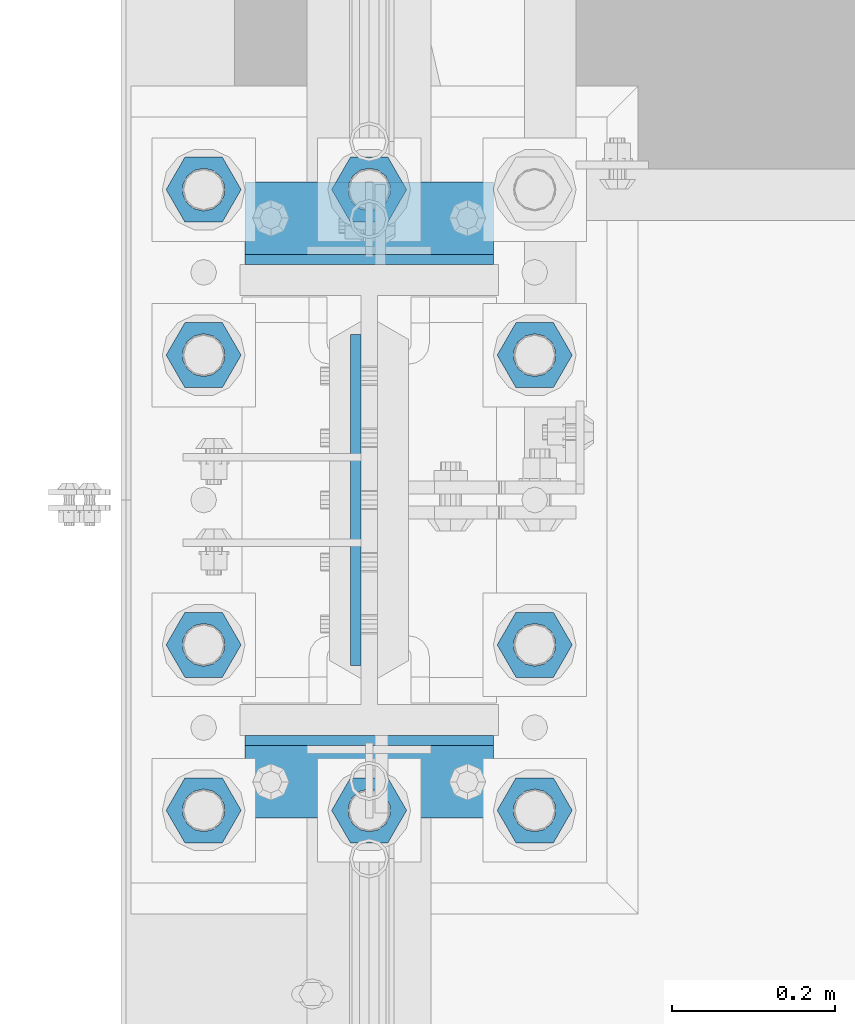
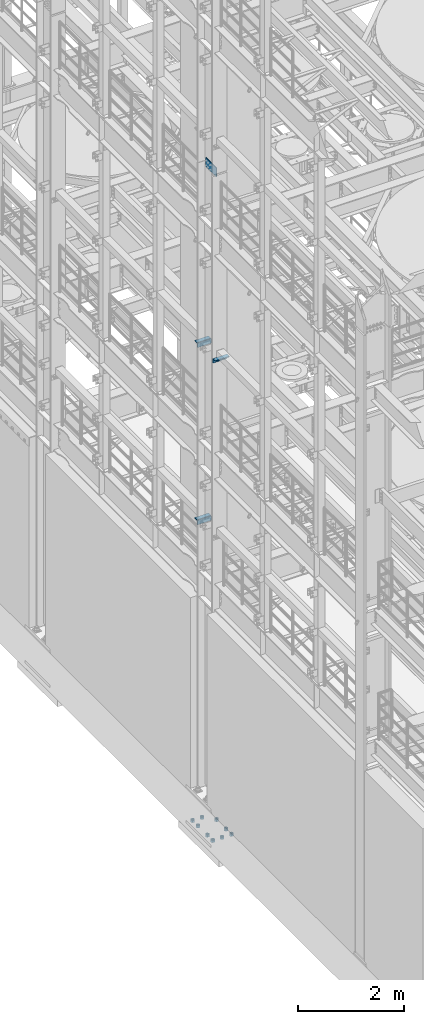
# One storey, part 1237 of 1876: 16 beams, 5 elements without a shape of their own.
"""IFC2X3 building model written with IfcOpenShell, lengths in millimetres."""

from ifc_helpers import new_model, si_unit, frame, origin_with_axes, place, context, subcontext, project, spatial, faceted_brep, material, type_object, element, aggregate, save


model = new_model("IFC2X3")

# Units and contexts
model_context = context("Model", 3, precision=1e-05, world=origin_with_axes())
body_context = subcontext(model_context, "Body", "Model", "MODEL_VIEW")
ifc_project = project(units=[si_unit("LENGTHUNIT", "METRE", prefix="MILLI"), si_unit("AREAUNIT", "SQUARE_METRE"), si_unit("VOLUMEUNIT", "CUBIC_METRE"), si_unit("MASSUNIT", "GRAM", prefix="KILO"), si_unit("TIMEUNIT", "SECOND"), si_unit("PLANEANGLEUNIT", "RADIAN"), si_unit("SOLIDANGLEUNIT", "STERADIAN"), si_unit("THERMODYNAMICTEMPERATUREUNIT", "DEGREE_CELSIUS"), si_unit("LUMINOUSINTENSITYUNIT", "LUMEN")], contexts=[model_context])

# Site, building, storey
site_placement = place(None, origin_with_axes())
site = spatial("IfcSite", under=ifc_project, at=site_placement, CompositionType="ELEMENT")
building_placement = place(site_placement, origin_with_axes())
building = spatial("IfcBuilding", under=site, at=building_placement, Name="Undefined", CompositionType="ELEMENT")
storey_placement = place(building_placement, origin_with_axes())
storey = spatial("IfcBuildingStorey", under=building, at=storey_placement, Name="Undefined", CompositionType="ELEMENT", Elevation=0.0)

# Assembly, beam
assembly_1_placement = place(storey_placement, origin_with_axes())
assembly_1 = element("IfcElementAssembly", 1, at=assembly_1_placement, inside=storey, Name="BEAM", AssemblyPlace="NOTDEFINED", PredefinedType="RIGID_FRAME")
ifc_material_1 = material(Name="STEEL/A36")
beam_type_1 = type_object("IfcBeamType", PredefinedType="NOTDEFINED")
beam_1_placement = place(assembly_1_placement, frame((-152.400000000001, 1177.925, 10339.3875), z_axis=(0.0, -1.0, 0.0), x_axis=(1.0, 0.0, 0.0)))
beam_1 = element("IfcBeam", 2, at=beam_1_placement, type_object=beam_type_1, material=ifc_material_1, Name="PLATE", context=body_context, shape_type="Brep", body=[
    faceted_brep([(0.0, 4.76250000000073, -44.4499999999998), (0.0, 4.76250000000073, 44.4499999999998), (304.799999999999, 4.76250000000073, 44.4499999999998), (304.799999999999, 4.76250000000073, -44.4499999999998), (0.0, -4.76250000000073, 44.4499999999998), (304.799999999999, -4.76250000000073, 44.4499999999998), (0.0, -4.76250000000073, -44.4499999999998), (304.799999999999, -4.76250000000073, -44.4499999999998)], [[[0, 1, 2, 3]], [[1, 4, 5, 2]], [[4, 6, 7, 5]], [[6, 0, 3, 7]], [[5, 7, 3, 2]], [[6, 4, 1, 0]]]),
])
aggregate(assembly_1, [beam_1])

assembly_2_placement = place(storey_placement, origin_with_axes())
assembly_2 = element("IfcElementAssembly", 3, at=assembly_2_placement, inside=storey, Name="BEAM", AssemblyPlace="NOTDEFINED", PredefinedType="RIGID_FRAME")
beam_2_placement = place(assembly_2_placement, frame((-152.400000000001, 1870.075, 10339.3875), z_axis=(0.0, 1.0, 0.0), x_axis=(1.0, 0.0, 0.0)))
beam_2 = element("IfcBeam", 4, at=beam_2_placement, type_object=beam_type_1, material=ifc_material_1, Name="PLATE", context=body_context, shape_type="Brep", body=[
    faceted_brep([(0.0, 4.76250000000073, -44.4499999999998), (0.0, 4.76250000000073, 44.4499999999998), (304.799999999999, 4.76250000000073, 44.4499999999998), (304.799999999999, 4.76250000000073, -44.4499999999998), (0.0, -4.76250000000073, 44.4499999999998), (304.799999999999, -4.76250000000073, 44.4499999999998), (0.0, -4.76250000000073, -44.4499999999998), (304.799999999999, -4.76250000000073, -44.4499999999998)], [[[0, 1, 2, 3]], [[1, 4, 5, 2]], [[4, 6, 7, 5]], [[6, 0, 3, 7]], [[5, 7, 3, 2]], [[6, 4, 1, 0]]]),
])
aggregate(assembly_2, [beam_2])

assembly_3_placement = place(storey_placement, origin_with_axes())
assembly_3 = element("IfcElementAssembly", 5, at=assembly_3_placement, inside=storey, Name="BEAM", AssemblyPlace="NOTDEFINED", PredefinedType="RIGID_FRAME")
beam_3_placement = place(assembly_3_placement, frame((-152.400000000001, 1870.075, 6249.9875), z_axis=(0.0, 1.0, 0.0), x_axis=(1.0, 0.0, 0.0)))
beam_3 = element("IfcBeam", 6, at=beam_3_placement, type_object=beam_type_1, material=ifc_material_1, Name="PLATE", context=body_context, shape_type="Brep", body=[
    faceted_brep([(0.0, 4.76250000000073, -44.4499999999998), (0.0, 4.76250000000073, 44.4499999999998), (304.799999999999, 4.76250000000073, 44.4499999999998), (304.799999999999, 4.76250000000073, -44.4499999999998), (0.0, -4.76250000000073, 44.4499999999998), (304.799999999999, -4.76250000000073, 44.4499999999998), (0.0, -4.76250000000073, -44.4499999999998), (304.799999999999, -4.76250000000073, -44.4499999999998)], [[[0, 1, 2, 3]], [[1, 4, 5, 2]], [[4, 6, 7, 5]], [[6, 0, 3, 7]], [[5, 7, 3, 2]], [[6, 4, 1, 0]]]),
])
aggregate(assembly_3, [beam_3])

# Assembly, beams
assembly_4_placement = place(storey_placement, origin_with_axes())
assembly_4 = element("IfcElementAssembly", 7, at=assembly_4_placement, inside=storey, Name="COLUMN", AssemblyPlace="NOTDEFINED", PredefinedType="RIGID_FRAME")
beam_type_2 = type_object("IfcBeamType", Name="L4X4X3/8", PredefinedType="NOTDEFINED")
beam_4_placement = place(assembly_4_placement, frame((-152.400000000001, 1184.275, 10283.825), z_axis=(0.0, -1.0, 0.0), x_axis=(1.0, 0.0, 0.0)))
beam_4 = element("IfcBeam", 8, at=beam_4_placement, type_object=beam_type_2, material=ifc_material_1, Name="ANGLE", ObjectType="L4X4X3/8", context=body_context, shape_type="Brep", body=[
    faceted_brep([(0.0, 50.7999999999993, -50.8000000000002), (0.0, 50.7999999999993, 50.8000000000002), (304.799999999999, 50.7999999999993, 50.8000000000002), (304.799999999999, 50.7999999999993, -50.8000000000002), (0.0, 41.2750000000015, 50.8000000000002), (304.799999999999, 41.2750000000015, 50.8000000000002), (0.0, 41.2750000000015, -41.2749999999996), (304.799999999999, 41.2750000000015, -41.2749999999996), (0.0, -50.7999999999993, -41.2749999999996), (304.799999999999, -50.7999999999993, -41.2749999999996), (0.0, -50.7999999999993, -50.8000000000002), (304.799999999999, -50.7999999999993, -50.8000000000002)], [[[0, 1, 2, 3]], [[1, 4, 5, 2]], [[4, 6, 7, 5]], [[6, 8, 9, 7]], [[8, 10, 11, 9]], [[10, 0, 3, 11]], [[5, 7, 9, 11, 3, 2]], [[10, 8, 6, 4, 1, 0]]]),
])
beam_5_placement = place(assembly_4_placement, frame((152.4, 1863.725, 10283.825), z_axis=(0.0, 1.0, 0.0), x_axis=(-1.0, 0.0, 0.0)))
beam_5 = element("IfcBeam", 9, at=beam_5_placement, type_object=beam_type_2, material=ifc_material_1, Name="ANGLE", ObjectType="L4X4X3/8", context=body_context, shape_type="Brep", body=[
    faceted_brep([(0.0, 50.7999999999993, -50.8000000000002), (0.0, 50.7999999999993, 50.8000000000002), (304.799999999999, 50.7999999999993, 50.8000000000002), (304.799999999999, 50.7999999999993, -50.8000000000002), (0.0, 41.2750000000015, 50.8000000000002), (304.799999999999, 41.2750000000015, 50.8000000000002), (0.0, 41.2750000000015, -41.2749999999996), (304.799999999999, 41.2750000000015, -41.2749999999996), (0.0, -50.7999999999993, -41.2749999999996), (304.799999999999, -50.7999999999993, -41.2749999999996), (0.0, -50.7999999999993, -50.8000000000002), (304.799999999999, -50.7999999999993, -50.8000000000002)], [[[0, 1, 2, 3]], [[1, 4, 5, 2]], [[4, 6, 7, 5]], [[6, 8, 9, 7]], [[8, 10, 11, 9]], [[10, 0, 3, 11]], [[5, 7, 9, 11, 3, 2]], [[10, 8, 6, 4, 1, 0]]]),
])
beam_6_placement = place(assembly_4_placement, frame((152.4, 1863.725, 6194.425), z_axis=(0.0, 1.0, 0.0), x_axis=(-1.0, 0.0, 0.0)))
beam_6 = element("IfcBeam", 10, at=beam_6_placement, type_object=beam_type_2, material=ifc_material_1, Name="ANGLE", ObjectType="L4X4X3/8", context=body_context, shape_type="Brep", body=[
    faceted_brep([(0.0, 50.7999999999993, -50.8000000000002), (0.0, 50.7999999999993, 50.8000000000002), (304.799999999999, 50.7999999999993, 50.8000000000002), (304.799999999999, 50.7999999999993, -50.8000000000002), (0.0, 41.2750000000015, 50.8000000000002), (304.799999999999, 41.2750000000015, 50.8000000000002), (0.0, 41.2750000000015, -41.2749999999996), (304.799999999999, 41.2750000000015, -41.2749999999996), (0.0, -50.7999999999993, -41.2749999999996), (304.799999999999, -50.7999999999993, -41.2749999999996), (0.0, -50.7999999999993, -50.8000000000002), (304.799999999999, -50.7999999999993, -50.8000000000002)], [[[0, 1, 2, 3]], [[1, 4, 5, 2]], [[4, 6, 7, 5]], [[6, 8, 9, 7]], [[8, 10, 11, 9]], [[10, 0, 3, 11]], [[5, 7, 9, 11, 3, 2]], [[10, 8, 6, 4, 1, 0]]]),
])
ifc_material_2 = material(Name="STEEL/A572-50")
beam_type_3 = type_object("IfcBeamType", PredefinedType="NOTDEFINED")
beam_7_placement = place(assembly_4_placement, frame((-16.6687499999999, 1524.0, 14636.75), z_axis=(0.0, 1.0, 0.0), x_axis=(0.0, 0.0, -1.0)))
beam_7 = element("IfcBeam", 11, at=beam_7_placement, type_object=beam_type_3, material=ifc_material_2, Name="PLATE", context=body_context, shape_type="Brep", body=[
    faceted_brep([(0.0, 6.35000000000036, -203.2), (0.0, 6.35000000000036, 203.2), (209.550000000001, 6.35000000000036, 203.2), (209.550000000001, 6.35000000000036, -203.2), (0.0, -6.35000000000036, 203.2), (209.550000000001, -6.35000000000036, 203.2), (0.0, -6.35000000000036, -203.2), (209.550000000001, -6.35000000000036, -203.2)], [[[0, 1, 2, 3]], [[1, 4, 5, 2]], [[4, 6, 7, 5]], [[6, 0, 3, 7]], [[5, 7, 3, 2]], [[6, 4, 1, 0]]]),
])
aggregate(assembly_4, [beam_4, beam_5, beam_6, beam_7])

assembly_5_placement = place(storey_placement, origin_with_axes())
assembly_5 = element("IfcElementAssembly", 12, at=assembly_5_placement, inside=storey, Name="TEMPLATE", AssemblyPlace="NOTDEFINED", PredefinedType="RIGID_FRAME")
ifc_material_3 = material(Name="STEEL/A563")
beam_type_4 = type_object("IfcBeamType", Name="2_HEAVY_HEX_NUT", PredefinedType="NOTDEFINED")
beam_8_placement = place(assembly_5_placement, frame((0.0, 1142.99999847412, -685.799998474121), z_axis=(0.0, -1.0, 0.0), x_axis=(0.0, 0.0, -1.0)))
beam_8 = element("IfcBeam", 13, at=beam_8_placement, type_object=beam_type_4, material=ifc_material_3, Name="NUT", ObjectType="2_HEAVY_HEX_NUT", context=body_context, shape_type="Brep", body=[
    faceted_brep([(0.0, -46.0369987487793, 9.09494701772928e-13), (0.0, -23.0184993743896, -39.869213104248), (50.8, -23.0184993743896, -39.869213104248), (50.8, -46.0369987487793, 9.09494701772928e-13), (0.0, 23.0184993743896, -39.869213104248), (50.8, 23.0184993743896, -39.869213104248), (0.0, 46.0369987487793, -9.09494701772928e-13), (50.8, 46.0369987487793, -9.09494701772928e-13), (0.0, 23.0184993743896, 39.869213104248), (50.8, 23.0184993743896, 39.869213104248), (0.0, -23.0184993743896, 39.869213104248), (50.8, -23.0184993743896, 39.869213104248), (0.0, 0.0, 26.1940002441406), (0.0, 11.3650617044514, 23.5999013092769), (50.8, 11.3650617044513, 23.5999013092771), (50.8, 0.0, 26.1940002441406), (0.0, 20.4791109456437, 16.3316083006703), (50.8, 20.4791109456439, 16.3316083006703), (0.0, 25.5370200498346, 5.82867859874477), (50.8, 25.5370200498343, 5.82867859874455), (0.0, 25.5370200498346, -5.82867859874477), (50.8, 25.5370200498343, -5.82867859874455), (0.0, 20.4791109456437, -16.3316083006703), (50.8, 20.4791109456439, -16.3316083006703), (0.0, 11.3650617044514, -23.5999013092769), (50.8, 11.3650617044514, -23.5999013092771), (0.0, 0.0, -26.1940002441406), (50.8, 0.0, -26.1940002441406), (0.0, -11.3650617044514, -23.5999013092769), (50.8, -11.3650617044513, -23.5999013092771), (0.0, -20.4791109456437, -16.3316083006703), (50.8, -20.4791109456439, -16.3316083006703), (0.0, -25.5370200498346, -5.82867859874477), (50.8, -25.5370200498343, -5.82867859874455), (0.0, -25.5370200498346, 5.82867859874477), (50.8, -25.5370200498343, 5.82867859874455), (0.0, -20.4791109456437, 16.3316083006703), (50.8, -20.4791109456439, 16.3316083006703), (0.0, -11.3650617044514, 23.5999013092769), (50.8, -11.3650617044514, 23.5999013092771)], [[[0, 1, 2, 3]], [[1, 4, 5, 2]], [[4, 6, 7, 5]], [[6, 8, 9, 7]], [[8, 10, 11, 9]], [[10, 0, 3, 11]], [[12, 13, 14, 15]], [[13, 16, 17, 14]], [[16, 18, 19, 17]], [[18, 20, 21, 19]], [[20, 22, 23, 21]], [[22, 24, 25, 23]], [[24, 26, 27, 25]], [[26, 28, 29, 27]], [[28, 30, 31, 29]], [[30, 32, 33, 31]], [[32, 34, 35, 33]], [[34, 36, 37, 35]], [[36, 38, 39, 37]], [[38, 12, 15, 39]], [[5, 7, 9, 11, 3, 2], [17, 19, 21, 23, 25, 27, 29, 31, 33, 35, 37, 39, 15, 14]], [[10, 8, 6, 4, 1, 0], [38, 36, 34, 32, 30, 28, 26, 24, 22, 20, 18, 16, 13, 12]]]),
])
beam_9_placement = place(assembly_5_placement, frame((-203.2, 1142.99999847412, -685.799998474121), z_axis=(0.0, -1.0, 0.0), x_axis=(0.0, 0.0, -1.0)))
beam_9 = element("IfcBeam", 14, at=beam_9_placement, type_object=beam_type_4, material=ifc_material_3, Name="NUT", ObjectType="2_HEAVY_HEX_NUT", context=body_context, shape_type="Brep", body=[
    faceted_brep([(0.0, -46.0369987487793, 9.09494701772928e-13), (0.0, -23.0184993743896, -39.869213104248), (50.8, -23.0184993743896, -39.869213104248), (50.8, -46.0369987487793, 9.09494701772928e-13), (0.0, 23.0184993743896, -39.869213104248), (50.8, 23.0184993743896, -39.869213104248), (0.0, 46.0369987487793, -9.09494701772928e-13), (50.8, 46.0369987487793, -9.09494701772928e-13), (0.0, 23.0184993743896, 39.869213104248), (50.8, 23.0184993743896, 39.869213104248), (0.0, -23.0184993743896, 39.869213104248), (50.8, -23.0184993743896, 39.869213104248), (0.0, 0.0, 26.1940002441406), (0.0, 11.3650617044514, 23.5999013092769), (50.8, 11.3650617044513, 23.5999013092771), (50.8, 0.0, 26.1940002441406), (0.0, 20.4791109456437, 16.3316083006703), (50.8, 20.4791109456439, 16.3316083006703), (0.0, 25.5370200498346, 5.82867859874477), (50.8, 25.5370200498343, 5.82867859874455), (0.0, 25.5370200498346, -5.82867859874477), (50.8, 25.5370200498343, -5.82867859874455), (0.0, 20.4791109456437, -16.3316083006703), (50.8, 20.4791109456439, -16.3316083006703), (0.0, 11.3650617044514, -23.5999013092769), (50.8, 11.3650617044514, -23.5999013092771), (0.0, 0.0, -26.1940002441406), (50.8, 0.0, -26.1940002441406), (0.0, -11.3650617044514, -23.5999013092769), (50.8, -11.3650617044513, -23.5999013092771), (0.0, -20.4791109456437, -16.3316083006703), (50.8, -20.4791109456439, -16.3316083006703), (0.0, -25.5370200498346, -5.82867859874477), (50.8, -25.5370200498343, -5.82867859874455), (0.0, -25.5370200498346, 5.82867859874477), (50.8, -25.5370200498343, 5.82867859874455), (0.0, -20.4791109456437, 16.3316083006703), (50.8, -20.4791109456439, 16.3316083006703), (0.0, -11.3650617044514, 23.5999013092769), (50.8, -11.3650617044514, 23.5999013092771)], [[[0, 1, 2, 3]], [[1, 4, 5, 2]], [[4, 6, 7, 5]], [[6, 8, 9, 7]], [[8, 10, 11, 9]], [[10, 0, 3, 11]], [[12, 13, 14, 15]], [[13, 16, 17, 14]], [[16, 18, 19, 17]], [[18, 20, 21, 19]], [[20, 22, 23, 21]], [[22, 24, 25, 23]], [[24, 26, 27, 25]], [[26, 28, 29, 27]], [[28, 30, 31, 29]], [[30, 32, 33, 31]], [[32, 34, 35, 33]], [[34, 36, 37, 35]], [[36, 38, 39, 37]], [[38, 12, 15, 39]], [[5, 7, 9, 11, 3, 2], [17, 19, 21, 23, 25, 27, 29, 31, 33, 35, 37, 39, 15, 14]], [[10, 8, 6, 4, 1, 0], [38, 36, 34, 32, 30, 28, 26, 24, 22, 20, 18, 16, 13, 12]]]),
])
beam_10_placement = place(assembly_5_placement, frame((203.2, 1142.99999847412, -685.799998474121), z_axis=(0.0, 1.0, 0.0), x_axis=(0.0, 0.0, -1.0)))
beam_10 = element("IfcBeam", 15, at=beam_10_placement, type_object=beam_type_4, material=ifc_material_3, Name="NUT", ObjectType="2_HEAVY_HEX_NUT", context=body_context, shape_type="Brep", body=[
    faceted_brep([(0.0, -46.0369987487793, 9.09494701772928e-13), (0.0, -23.0184993743896, -39.869213104248), (50.8, -23.0184993743896, -39.869213104248), (50.8, -46.0369987487793, 9.09494701772928e-13), (0.0, 23.0184993743896, -39.869213104248), (50.8, 23.0184993743896, -39.869213104248), (0.0, 46.0369987487793, -9.09494701772928e-13), (50.8, 46.0369987487793, -9.09494701772928e-13), (0.0, 23.0184993743896, 39.869213104248), (50.8, 23.0184993743896, 39.869213104248), (0.0, -23.0184993743896, 39.869213104248), (50.8, -23.0184993743896, 39.869213104248), (0.0, 0.0, 26.1940002441406), (0.0, 11.3650617044514, 23.5999013092769), (50.8, 11.3650617044513, 23.5999013092771), (50.8, 0.0, 26.1940002441406), (0.0, 20.4791109456437, 16.3316083006703), (50.8, 20.4791109456439, 16.3316083006703), (0.0, 25.5370200498346, 5.82867859874477), (50.8, 25.5370200498343, 5.82867859874455), (0.0, 25.5370200498346, -5.82867859874477), (50.8, 25.5370200498343, -5.82867859874455), (0.0, 20.4791109456437, -16.3316083006703), (50.8, 20.4791109456439, -16.3316083006703), (0.0, 11.3650617044514, -23.5999013092769), (50.8, 11.3650617044514, -23.5999013092771), (0.0, 0.0, -26.1940002441406), (50.8, 0.0, -26.1940002441406), (0.0, -11.3650617044514, -23.5999013092769), (50.8, -11.3650617044513, -23.5999013092771), (0.0, -20.4791109456437, -16.3316083006703), (50.8, -20.4791109456439, -16.3316083006703), (0.0, -25.5370200498346, -5.82867859874477), (50.8, -25.5370200498343, -5.82867859874455), (0.0, -25.5370200498346, 5.82867859874477), (50.8, -25.5370200498343, 5.82867859874455), (0.0, -20.4791109456437, 16.3316083006703), (50.8, -20.4791109456439, 16.3316083006703), (0.0, -11.3650617044514, 23.5999013092769), (50.8, -11.3650617044514, 23.5999013092771)], [[[0, 1, 2, 3]], [[1, 4, 5, 2]], [[4, 6, 7, 5]], [[6, 8, 9, 7]], [[8, 10, 11, 9]], [[10, 0, 3, 11]], [[12, 13, 14, 15]], [[13, 16, 17, 14]], [[16, 18, 19, 17]], [[18, 20, 21, 19]], [[20, 22, 23, 21]], [[22, 24, 25, 23]], [[24, 26, 27, 25]], [[26, 28, 29, 27]], [[28, 30, 31, 29]], [[30, 32, 33, 31]], [[32, 34, 35, 33]], [[34, 36, 37, 35]], [[36, 38, 39, 37]], [[38, 12, 15, 39]], [[5, 7, 9, 11, 3, 2], [17, 19, 21, 23, 25, 27, 29, 31, 33, 35, 37, 39, 15, 14]], [[10, 8, 6, 4, 1, 0], [38, 36, 34, 32, 30, 28, 26, 24, 22, 20, 18, 16, 13, 12]]]),
])
beam_11_placement = place(assembly_5_placement, frame((-203.2, 1346.19999847412, -685.799998474121), z_axis=(0.0, -1.0, 0.0), x_axis=(0.0, 0.0, -1.0)))
beam_11 = element("IfcBeam", 16, at=beam_11_placement, type_object=beam_type_4, material=ifc_material_3, Name="NUT", ObjectType="2_HEAVY_HEX_NUT", context=body_context, shape_type="Brep", body=[
    faceted_brep([(0.0, -46.0369987487793, 9.09494701772928e-13), (0.0, -23.0184993743896, -39.869213104248), (50.8, -23.0184993743896, -39.869213104248), (50.8, -46.0369987487793, 9.09494701772928e-13), (0.0, 23.0184993743896, -39.869213104248), (50.8, 23.0184993743896, -39.869213104248), (0.0, 46.0369987487793, -9.09494701772928e-13), (50.8, 46.0369987487793, -9.09494701772928e-13), (0.0, 23.0184993743896, 39.869213104248), (50.8, 23.0184993743896, 39.869213104248), (0.0, -23.0184993743896, 39.869213104248), (50.8, -23.0184993743896, 39.869213104248), (0.0, 0.0, 26.1940002441406), (0.0, 11.3650617044514, 23.5999013092769), (50.8, 11.3650617044513, 23.5999013092771), (50.8, 0.0, 26.1940002441406), (0.0, 20.4791109456437, 16.3316083006703), (50.8, 20.4791109456439, 16.3316083006703), (0.0, 25.5370200498346, 5.82867859874477), (50.8, 25.5370200498343, 5.82867859874455), (0.0, 25.5370200498346, -5.82867859874477), (50.8, 25.5370200498343, -5.82867859874455), (0.0, 20.4791109456437, -16.3316083006703), (50.8, 20.4791109456439, -16.3316083006703), (0.0, 11.3650617044514, -23.5999013092769), (50.8, 11.3650617044514, -23.5999013092771), (0.0, 0.0, -26.1940002441406), (50.8, 0.0, -26.1940002441406), (0.0, -11.3650617044514, -23.5999013092769), (50.8, -11.3650617044513, -23.5999013092771), (0.0, -20.4791109456437, -16.3316083006703), (50.8, -20.4791109456439, -16.3316083006703), (0.0, -25.5370200498346, -5.82867859874477), (50.8, -25.5370200498343, -5.82867859874455), (0.0, -25.5370200498346, 5.82867859874477), (50.8, -25.5370200498343, 5.82867859874455), (0.0, -20.4791109456437, 16.3316083006703), (50.8, -20.4791109456439, 16.3316083006703), (0.0, -11.3650617044514, 23.5999013092769), (50.8, -11.3650617044514, 23.5999013092771)], [[[0, 1, 2, 3]], [[1, 4, 5, 2]], [[4, 6, 7, 5]], [[6, 8, 9, 7]], [[8, 10, 11, 9]], [[10, 0, 3, 11]], [[12, 13, 14, 15]], [[13, 16, 17, 14]], [[16, 18, 19, 17]], [[18, 20, 21, 19]], [[20, 22, 23, 21]], [[22, 24, 25, 23]], [[24, 26, 27, 25]], [[26, 28, 29, 27]], [[28, 30, 31, 29]], [[30, 32, 33, 31]], [[32, 34, 35, 33]], [[34, 36, 37, 35]], [[36, 38, 39, 37]], [[38, 12, 15, 39]], [[5, 7, 9, 11, 3, 2], [17, 19, 21, 23, 25, 27, 29, 31, 33, 35, 37, 39, 15, 14]], [[10, 8, 6, 4, 1, 0], [38, 36, 34, 32, 30, 28, 26, 24, 22, 20, 18, 16, 13, 12]]]),
])
beam_12_placement = place(assembly_5_placement, frame((203.2, 1346.19999847412, -685.799998474121), z_axis=(0.0, 1.0, 0.0), x_axis=(0.0, 0.0, -1.0)))
beam_12 = element("IfcBeam", 17, at=beam_12_placement, type_object=beam_type_4, material=ifc_material_3, Name="NUT", ObjectType="2_HEAVY_HEX_NUT", context=body_context, shape_type="Brep", body=[
    faceted_brep([(0.0, -46.0369987487793, 9.09494701772928e-13), (0.0, -23.0184993743896, -39.869213104248), (50.8, -23.0184993743896, -39.869213104248), (50.8, -46.0369987487793, 9.09494701772928e-13), (0.0, 23.0184993743896, -39.869213104248), (50.8, 23.0184993743896, -39.869213104248), (0.0, 46.0369987487793, -9.09494701772928e-13), (50.8, 46.0369987487793, -9.09494701772928e-13), (0.0, 23.0184993743896, 39.869213104248), (50.8, 23.0184993743896, 39.869213104248), (0.0, -23.0184993743896, 39.869213104248), (50.8, -23.0184993743896, 39.869213104248), (0.0, 0.0, 26.1940002441406), (0.0, 11.3650617044514, 23.5999013092769), (50.8, 11.3650617044513, 23.5999013092771), (50.8, 0.0, 26.1940002441406), (0.0, 20.4791109456437, 16.3316083006703), (50.8, 20.4791109456439, 16.3316083006703), (0.0, 25.5370200498346, 5.82867859874477), (50.8, 25.5370200498343, 5.82867859874455), (0.0, 25.5370200498346, -5.82867859874477), (50.8, 25.5370200498343, -5.82867859874455), (0.0, 20.4791109456437, -16.3316083006703), (50.8, 20.4791109456439, -16.3316083006703), (0.0, 11.3650617044514, -23.5999013092769), (50.8, 11.3650617044514, -23.5999013092771), (0.0, 0.0, -26.1940002441406), (50.8, 0.0, -26.1940002441406), (0.0, -11.3650617044514, -23.5999013092769), (50.8, -11.3650617044513, -23.5999013092771), (0.0, -20.4791109456437, -16.3316083006703), (50.8, -20.4791109456439, -16.3316083006703), (0.0, -25.5370200498346, -5.82867859874477), (50.8, -25.5370200498343, -5.82867859874455), (0.0, -25.5370200498346, 5.82867859874477), (50.8, -25.5370200498343, 5.82867859874455), (0.0, -20.4791109456437, 16.3316083006703), (50.8, -20.4791109456439, 16.3316083006703), (0.0, -11.3650617044514, 23.5999013092769), (50.8, -11.3650617044514, 23.5999013092771)], [[[0, 1, 2, 3]], [[1, 4, 5, 2]], [[4, 6, 7, 5]], [[6, 8, 9, 7]], [[8, 10, 11, 9]], [[10, 0, 3, 11]], [[12, 13, 14, 15]], [[13, 16, 17, 14]], [[16, 18, 19, 17]], [[18, 20, 21, 19]], [[20, 22, 23, 21]], [[22, 24, 25, 23]], [[24, 26, 27, 25]], [[26, 28, 29, 27]], [[28, 30, 31, 29]], [[30, 32, 33, 31]], [[32, 34, 35, 33]], [[34, 36, 37, 35]], [[36, 38, 39, 37]], [[38, 12, 15, 39]], [[5, 7, 9, 11, 3, 2], [17, 19, 21, 23, 25, 27, 29, 31, 33, 35, 37, 39, 15, 14]], [[10, 8, 6, 4, 1, 0], [38, 36, 34, 32, 30, 28, 26, 24, 22, 20, 18, 16, 13, 12]]]),
])
beam_13_placement = place(assembly_5_placement, frame((-203.2, 1701.79999847412, -685.799998474121), z_axis=(0.0, -1.0, 0.0), x_axis=(0.0, 0.0, -1.0)))
beam_13 = element("IfcBeam", 18, at=beam_13_placement, type_object=beam_type_4, material=ifc_material_3, Name="NUT", ObjectType="2_HEAVY_HEX_NUT", context=body_context, shape_type="Brep", body=[
    faceted_brep([(0.0, -46.0369987487793, 9.09494701772928e-13), (0.0, -23.0184993743896, -39.869213104248), (50.8, -23.0184993743896, -39.869213104248), (50.8, -46.0369987487793, 9.09494701772928e-13), (0.0, 23.0184993743896, -39.869213104248), (50.8, 23.0184993743896, -39.869213104248), (0.0, 46.0369987487793, -9.09494701772928e-13), (50.8, 46.0369987487793, -9.09494701772928e-13), (0.0, 23.0184993743896, 39.869213104248), (50.8, 23.0184993743896, 39.869213104248), (0.0, -23.0184993743896, 39.869213104248), (50.8, -23.0184993743896, 39.869213104248), (0.0, 0.0, 26.1940002441406), (0.0, 11.3650617044514, 23.5999013092769), (50.8, 11.3650617044513, 23.5999013092771), (50.8, 0.0, 26.1940002441406), (0.0, 20.4791109456437, 16.3316083006703), (50.8, 20.4791109456439, 16.3316083006703), (0.0, 25.5370200498346, 5.82867859874477), (50.8, 25.5370200498343, 5.82867859874455), (0.0, 25.5370200498346, -5.82867859874477), (50.8, 25.5370200498343, -5.82867859874455), (0.0, 20.4791109456437, -16.3316083006703), (50.8, 20.4791109456439, -16.3316083006703), (0.0, 11.3650617044514, -23.5999013092769), (50.8, 11.3650617044514, -23.5999013092771), (0.0, 0.0, -26.1940002441406), (50.8, 0.0, -26.1940002441406), (0.0, -11.3650617044514, -23.5999013092769), (50.8, -11.3650617044513, -23.5999013092771), (0.0, -20.4791109456437, -16.3316083006703), (50.8, -20.4791109456439, -16.3316083006703), (0.0, -25.5370200498346, -5.82867859874477), (50.8, -25.5370200498343, -5.82867859874455), (0.0, -25.5370200498346, 5.82867859874477), (50.8, -25.5370200498343, 5.82867859874455), (0.0, -20.4791109456437, 16.3316083006703), (50.8, -20.4791109456439, 16.3316083006703), (0.0, -11.3650617044514, 23.5999013092769), (50.8, -11.3650617044514, 23.5999013092771)], [[[0, 1, 2, 3]], [[1, 4, 5, 2]], [[4, 6, 7, 5]], [[6, 8, 9, 7]], [[8, 10, 11, 9]], [[10, 0, 3, 11]], [[12, 13, 14, 15]], [[13, 16, 17, 14]], [[16, 18, 19, 17]], [[18, 20, 21, 19]], [[20, 22, 23, 21]], [[22, 24, 25, 23]], [[24, 26, 27, 25]], [[26, 28, 29, 27]], [[28, 30, 31, 29]], [[30, 32, 33, 31]], [[32, 34, 35, 33]], [[34, 36, 37, 35]], [[36, 38, 39, 37]], [[38, 12, 15, 39]], [[5, 7, 9, 11, 3, 2], [17, 19, 21, 23, 25, 27, 29, 31, 33, 35, 37, 39, 15, 14]], [[10, 8, 6, 4, 1, 0], [38, 36, 34, 32, 30, 28, 26, 24, 22, 20, 18, 16, 13, 12]]]),
])
beam_14_placement = place(assembly_5_placement, frame((203.2, 1701.79999847412, -685.799998474121), z_axis=(0.0, 1.0, 0.0), x_axis=(0.0, 0.0, -1.0)))
beam_14 = element("IfcBeam", 19, at=beam_14_placement, type_object=beam_type_4, material=ifc_material_3, Name="NUT", ObjectType="2_HEAVY_HEX_NUT", context=body_context, shape_type="Brep", body=[
    faceted_brep([(0.0, -46.0369987487793, 9.09494701772928e-13), (0.0, -23.0184993743896, -39.869213104248), (50.8, -23.0184993743896, -39.869213104248), (50.8, -46.0369987487793, 9.09494701772928e-13), (0.0, 23.0184993743896, -39.869213104248), (50.8, 23.0184993743896, -39.869213104248), (0.0, 46.0369987487793, -9.09494701772928e-13), (50.8, 46.0369987487793, -9.09494701772928e-13), (0.0, 23.0184993743896, 39.869213104248), (50.8, 23.0184993743896, 39.869213104248), (0.0, -23.0184993743896, 39.869213104248), (50.8, -23.0184993743896, 39.869213104248), (0.0, 0.0, 26.1940002441406), (0.0, 11.3650617044514, 23.5999013092769), (50.8, 11.3650617044513, 23.5999013092771), (50.8, 0.0, 26.1940002441406), (0.0, 20.4791109456437, 16.3316083006703), (50.8, 20.4791109456439, 16.3316083006703), (0.0, 25.5370200498346, 5.82867859874477), (50.8, 25.5370200498343, 5.82867859874455), (0.0, 25.5370200498346, -5.82867859874477), (50.8, 25.5370200498343, -5.82867859874455), (0.0, 20.4791109456437, -16.3316083006703), (50.8, 20.4791109456439, -16.3316083006703), (0.0, 11.3650617044514, -23.5999013092769), (50.8, 11.3650617044514, -23.5999013092771), (0.0, 0.0, -26.1940002441406), (50.8, 0.0, -26.1940002441406), (0.0, -11.3650617044514, -23.5999013092769), (50.8, -11.3650617044513, -23.5999013092771), (0.0, -20.4791109456437, -16.3316083006703), (50.8, -20.4791109456439, -16.3316083006703), (0.0, -25.5370200498346, -5.82867859874477), (50.8, -25.5370200498343, -5.82867859874455), (0.0, -25.5370200498346, 5.82867859874477), (50.8, -25.5370200498343, 5.82867859874455), (0.0, -20.4791109456437, 16.3316083006703), (50.8, -20.4791109456439, 16.3316083006703), (0.0, -11.3650617044514, 23.5999013092769), (50.8, -11.3650617044514, 23.5999013092771)], [[[0, 1, 2, 3]], [[1, 4, 5, 2]], [[4, 6, 7, 5]], [[6, 8, 9, 7]], [[8, 10, 11, 9]], [[10, 0, 3, 11]], [[12, 13, 14, 15]], [[13, 16, 17, 14]], [[16, 18, 19, 17]], [[18, 20, 21, 19]], [[20, 22, 23, 21]], [[22, 24, 25, 23]], [[24, 26, 27, 25]], [[26, 28, 29, 27]], [[28, 30, 31, 29]], [[30, 32, 33, 31]], [[32, 34, 35, 33]], [[34, 36, 37, 35]], [[36, 38, 39, 37]], [[38, 12, 15, 39]], [[5, 7, 9, 11, 3, 2], [17, 19, 21, 23, 25, 27, 29, 31, 33, 35, 37, 39, 15, 14]], [[10, 8, 6, 4, 1, 0], [38, 36, 34, 32, 30, 28, 26, 24, 22, 20, 18, 16, 13, 12]]]),
])
beam_15_placement = place(assembly_5_placement, frame((-203.2, 1904.99999847412, -685.799998474121), z_axis=(0.0, -1.0, 0.0), x_axis=(0.0, 0.0, -1.0)))
beam_15 = element("IfcBeam", 20, at=beam_15_placement, type_object=beam_type_4, material=ifc_material_3, Name="NUT", ObjectType="2_HEAVY_HEX_NUT", context=body_context, shape_type="Brep", body=[
    faceted_brep([(0.0, -46.0369987487793, 9.09494701772928e-13), (0.0, -23.0184993743896, -39.869213104248), (50.8, -23.0184993743896, -39.869213104248), (50.8, -46.0369987487793, 9.09494701772928e-13), (0.0, 23.0184993743896, -39.869213104248), (50.8, 23.0184993743896, -39.869213104248), (0.0, 46.0369987487793, -9.09494701772928e-13), (50.8, 46.0369987487793, -9.09494701772928e-13), (0.0, 23.0184993743896, 39.869213104248), (50.8, 23.0184993743896, 39.869213104248), (0.0, -23.0184993743896, 39.869213104248), (50.8, -23.0184993743896, 39.869213104248), (0.0, 0.0, 26.1940002441406), (0.0, 11.3650617044514, 23.5999013092769), (50.8, 11.3650617044513, 23.5999013092771), (50.8, 0.0, 26.1940002441406), (0.0, 20.4791109456437, 16.3316083006703), (50.8, 20.4791109456439, 16.3316083006703), (0.0, 25.5370200498346, 5.82867859874477), (50.8, 25.5370200498343, 5.82867859874455), (0.0, 25.5370200498346, -5.82867859874477), (50.8, 25.5370200498343, -5.82867859874455), (0.0, 20.4791109456437, -16.3316083006703), (50.8, 20.4791109456439, -16.3316083006703), (0.0, 11.3650617044514, -23.5999013092769), (50.8, 11.3650617044514, -23.5999013092771), (0.0, 0.0, -26.1940002441406), (50.8, 0.0, -26.1940002441406), (0.0, -11.3650617044514, -23.5999013092769), (50.8, -11.3650617044513, -23.5999013092771), (0.0, -20.4791109456437, -16.3316083006703), (50.8, -20.4791109456439, -16.3316083006703), (0.0, -25.5370200498346, -5.82867859874477), (50.8, -25.5370200498343, -5.82867859874455), (0.0, -25.5370200498346, 5.82867859874477), (50.8, -25.5370200498343, 5.82867859874455), (0.0, -20.4791109456437, 16.3316083006703), (50.8, -20.4791109456439, 16.3316083006703), (0.0, -11.3650617044514, 23.5999013092769), (50.8, -11.3650617044514, 23.5999013092771)], [[[0, 1, 2, 3]], [[1, 4, 5, 2]], [[4, 6, 7, 5]], [[6, 8, 9, 7]], [[8, 10, 11, 9]], [[10, 0, 3, 11]], [[12, 13, 14, 15]], [[13, 16, 17, 14]], [[16, 18, 19, 17]], [[18, 20, 21, 19]], [[20, 22, 23, 21]], [[22, 24, 25, 23]], [[24, 26, 27, 25]], [[26, 28, 29, 27]], [[28, 30, 31, 29]], [[30, 32, 33, 31]], [[32, 34, 35, 33]], [[34, 36, 37, 35]], [[36, 38, 39, 37]], [[38, 12, 15, 39]], [[5, 7, 9, 11, 3, 2], [17, 19, 21, 23, 25, 27, 29, 31, 33, 35, 37, 39, 15, 14]], [[10, 8, 6, 4, 1, 0], [38, 36, 34, 32, 30, 28, 26, 24, 22, 20, 18, 16, 13, 12]]]),
])
beam_16_placement = place(assembly_5_placement, frame((0.0, 1904.99999847412, -685.799998474121), z_axis=(0.0, -1.0, 0.0), x_axis=(0.0, 0.0, -1.0)))
beam_16 = element("IfcBeam", 21, at=beam_16_placement, type_object=beam_type_4, material=ifc_material_3, Name="NUT", ObjectType="2_HEAVY_HEX_NUT", context=body_context, shape_type="Brep", body=[
    faceted_brep([(0.0, -46.0369987487793, 9.09494701772928e-13), (0.0, -23.0184993743896, -39.869213104248), (50.8, -23.0184993743896, -39.869213104248), (50.8, -46.0369987487793, 9.09494701772928e-13), (0.0, 23.0184993743896, -39.869213104248), (50.8, 23.0184993743896, -39.869213104248), (0.0, 46.0369987487793, -9.09494701772928e-13), (50.8, 46.0369987487793, -9.09494701772928e-13), (0.0, 23.0184993743896, 39.869213104248), (50.8, 23.0184993743896, 39.869213104248), (0.0, -23.0184993743896, 39.869213104248), (50.8, -23.0184993743896, 39.869213104248), (0.0, 0.0, 26.1940002441406), (0.0, 11.3650617044514, 23.5999013092769), (50.8, 11.3650617044513, 23.5999013092771), (50.8, 0.0, 26.1940002441406), (0.0, 20.4791109456437, 16.3316083006703), (50.8, 20.4791109456439, 16.3316083006703), (0.0, 25.5370200498346, 5.82867859874477), (50.8, 25.5370200498343, 5.82867859874455), (0.0, 25.5370200498346, -5.82867859874477), (50.8, 25.5370200498343, -5.82867859874455), (0.0, 20.4791109456437, -16.3316083006703), (50.8, 20.4791109456439, -16.3316083006703), (0.0, 11.3650617044514, -23.5999013092769), (50.8, 11.3650617044514, -23.5999013092771), (0.0, 0.0, -26.1940002441406), (50.8, 0.0, -26.1940002441406), (0.0, -11.3650617044514, -23.5999013092769), (50.8, -11.3650617044513, -23.5999013092771), (0.0, -20.4791109456437, -16.3316083006703), (50.8, -20.4791109456439, -16.3316083006703), (0.0, -25.5370200498346, -5.82867859874477), (50.8, -25.5370200498343, -5.82867859874455), (0.0, -25.5370200498346, 5.82867859874477), (50.8, -25.5370200498343, 5.82867859874455), (0.0, -20.4791109456437, 16.3316083006703), (50.8, -20.4791109456439, 16.3316083006703), (0.0, -11.3650617044514, 23.5999013092769), (50.8, -11.3650617044514, 23.5999013092771)], [[[0, 1, 2, 3]], [[1, 4, 5, 2]], [[4, 6, 7, 5]], [[6, 8, 9, 7]], [[8, 10, 11, 9]], [[10, 0, 3, 11]], [[12, 13, 14, 15]], [[13, 16, 17, 14]], [[16, 18, 19, 17]], [[18, 20, 21, 19]], [[20, 22, 23, 21]], [[22, 24, 25, 23]], [[24, 26, 27, 25]], [[26, 28, 29, 27]], [[28, 30, 31, 29]], [[30, 32, 33, 31]], [[32, 34, 35, 33]], [[34, 36, 37, 35]], [[36, 38, 39, 37]], [[38, 12, 15, 39]], [[5, 7, 9, 11, 3, 2], [17, 19, 21, 23, 25, 27, 29, 31, 33, 35, 37, 39, 15, 14]], [[10, 8, 6, 4, 1, 0], [38, 36, 34, 32, 30, 28, 26, 24, 22, 20, 18, 16, 13, 12]]]),
])
aggregate(assembly_5, [beam_8, beam_9, beam_10, beam_11, beam_12, beam_13, beam_14, beam_15, beam_16])

save(model, "model.ifc")
